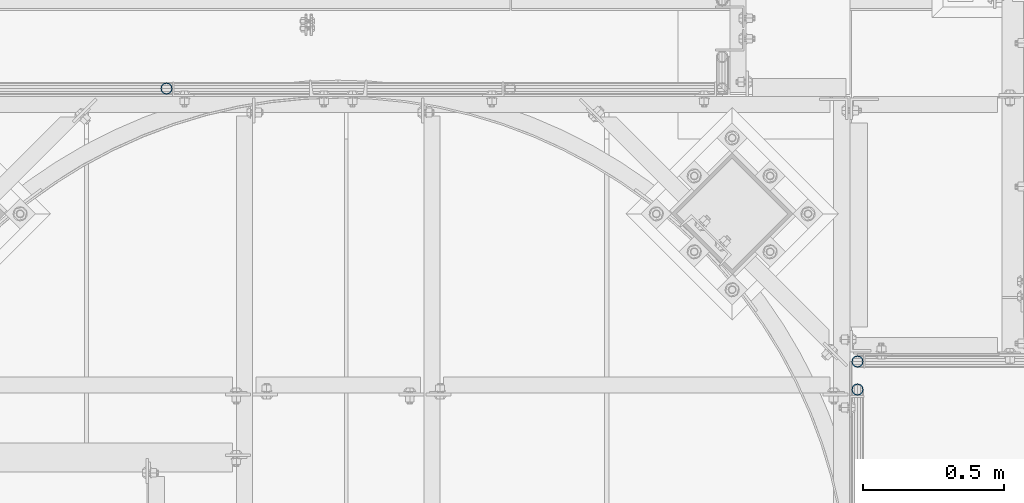
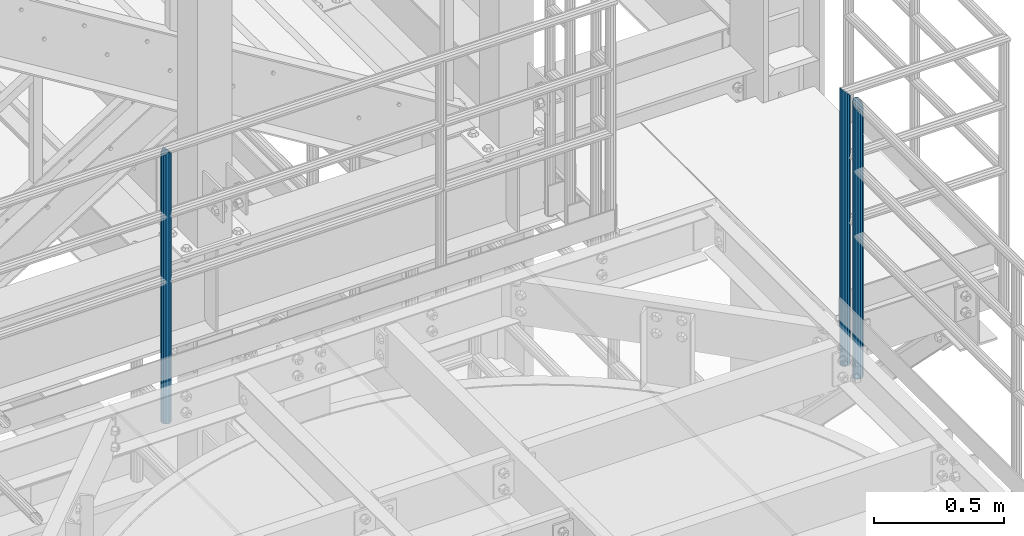
# One storey, part 578 of 1876: 3 columns, 3 elements without a shape of their own.
"""IFC2X3 building model written with IfcOpenShell, lengths in millimetres."""

from ifc_helpers import new_model, si_unit, frame, origin_with_axes, place, context, subcontext, project, spatial, faceted_brep, material, type_object, element, aggregate, save


model = new_model("IFC2X3")

# Units and contexts
model_context = context("Model", 3, precision=1e-05, world=origin_with_axes())
body_context = subcontext(model_context, "Body", "Model", "MODEL_VIEW")
ifc_project = project(units=[si_unit("LENGTHUNIT", "METRE", prefix="MILLI"), si_unit("AREAUNIT", "SQUARE_METRE"), si_unit("VOLUMEUNIT", "CUBIC_METRE"), si_unit("MASSUNIT", "GRAM", prefix="KILO"), si_unit("TIMEUNIT", "SECOND"), si_unit("PLANEANGLEUNIT", "RADIAN"), si_unit("SOLIDANGLEUNIT", "STERADIAN"), si_unit("THERMODYNAMICTEMPERATUREUNIT", "DEGREE_CELSIUS"), si_unit("LUMINOUSINTENSITYUNIT", "LUMEN")], contexts=[model_context])

# Site, building, storey
site_placement = place(None, origin_with_axes())
site = spatial("IfcSite", under=ifc_project, at=site_placement, CompositionType="ELEMENT")
building_placement = place(site_placement, origin_with_axes())
building = spatial("IfcBuilding", under=site, at=building_placement, Name="Undefined", CompositionType="ELEMENT")
storey_placement = place(building_placement, origin_with_axes())
storey = spatial("IfcBuildingStorey", under=building, at=storey_placement, Name="Undefined", CompositionType="ELEMENT", Elevation=0.0)

# Assembly, column
assembly_1_placement = place(storey_placement, origin_with_axes())
assembly_1 = element("IfcElementAssembly", 1, at=assembly_1_placement, inside=storey, Name="HANDRAIL", AssemblyPlace="NOTDEFINED", PredefinedType="RIGID_FRAME")
ifc_material = material()
column_type = type_object("IfcColumnType", Name="PIPE1-1/4STD", PredefinedType="NOTDEFINED")
column_1_placement = place(assembly_1_placement, frame((4572.00474593762, -7694.13240429563, 7813.675), z_axis=(0.0, 1.0, 0.0), x_axis=(0.0, 0.0, 1.0)))
column_1 = element("IfcColumn", 2, at=column_1_placement, type_object=column_type, material=ifc_material, Name="POST", ObjectType="PIPE1-1/4STD", context=body_context, shape_type="Brep", body=[
    faceted_brep([(1276.35, 0.0, -21.0820000000003), (1265.809, 10.5410000000002, -18.2575475625836), (1265.809, -10.5410000000002, -18.2575475625836), (1257.61603877328, 15.1779612267264, 8.76299999999992), (1255.268, 17.5259999999998, 0.0), (1255.268, 21.0820000000003, 0.0), (1258.09245243742, 18.2575475625836, 10.5410000000002), (1258.09245243742, 13.3999612267262, 10.5410000000002), (1258.09245243742, 13.3999612267262, -10.5410000000002), (1258.09245243742, 18.2575475625836, -10.5410000000002), (1257.61603877328, 15.1779612267264, -8.76299999999992), (1262.72937633681, 8.76299999999992, -15.1779612267255), (1265.07741511008, 0.0, -17.5259999999998), (1262.72937633681, -8.76299999999992, -15.1779612267255), (1258.09245243741, -13.3999612267244, -10.541000000002), (1258.09245243742, -18.2575475625836, -10.5409999999993), (1257.61602877145, -15.1779612267264, -8.76300000000083), (1255.268, -17.5259999999998, 0.0), (1255.268, -21.0820000000003, 0.0), (1257.61604877511, -15.1779612267264, 8.76300000000083), (1258.09245243741, -13.399961226728, 10.5409999999983), (1258.09245243742, -18.2575475625836, 10.5409999999993), (1276.35, 0.0, 21.0820000000003), (1265.809, -10.5410000000002, 18.2575475625836), (1265.809, 10.5410000000002, 18.2575475625836), (1262.72941366414, -8.76299999999992, 15.1779612267264), (1265.07745243742, 0.0, 17.5259999999998), (1262.72941366414, 8.76299999999992, 15.1779612267264), (0.0, -18.2575475625836, -10.5409999999993), (0.0, -10.5410000000002, -18.2575475625836), (-4.28826751885936e-09, 0.0, -21.0820000000003), (0.0, 10.5410000000002, -18.2575475625836), (0.0, 18.2575475625836, -10.5409999999993), (9.09494701772928e-13, 21.0820000000003, 0.0), (0.0, 18.2575475625836, 10.5409999999993), (0.0, 10.5410000000002, 18.2575475625836), (0.0, 0.0, 21.0820000000003), (0.0, -18.2575475625836, 10.5409999999993), (9.09494701772928e-13, -21.0820000000003, 0.0), (0.0, -10.5410000000002, 18.2575475625836), (0.0, -15.1779612267264, -8.76300000000083), (0.0, -8.76299999999992, -15.1779612267255), (0.0, 0.0, -17.5259999999998), (0.0, 8.76299999999992, -15.1779612267255), (0.0, 15.1779612267264, -8.76300000000083), (0.0, 17.5259999999998, 0.0), (0.0, 15.1779612267264, 8.76300000000083), (0.0, 8.76299999999992, 15.1779612267255), (0.0, 0.0, 17.5259999999998), (0.0, -8.76299999999992, 15.1779612267255), (0.0, -15.1779612267264, 8.76300000000083), (0.0, -17.5259999999998, 0.0)], [[[0, 1, 2]], [[3, 4, 5, 6, 7]], [[8, 9, 5, 4, 10]], [[2, 1, 9, 8, 11, 12, 13, 14, 15]], [[15, 14, 16, 17, 18]], [[18, 17, 19, 20, 21]], [[22, 23, 24]], [[21, 20, 25, 26, 27, 7, 6, 24, 23]], [[28, 29, 2, 15]], [[29, 30, 0, 2]], [[30, 31, 1, 0]], [[31, 32, 9, 1]], [[32, 33, 5, 9]], [[33, 34, 6, 5]], [[34, 35, 24, 6]], [[35, 36, 22, 24]], [[37, 38, 18, 21]], [[39, 37, 21, 23]], [[36, 39, 23, 22]], [[38, 28, 15, 18]], [[37, 39, 36, 35, 34, 33, 32, 31, 30, 29, 28, 38], [40, 41, 42, 43, 44, 45, 46, 47, 48, 49, 50, 51]], [[49, 48, 26, 25]], [[19, 50, 49, 25, 20]], [[51, 50, 19, 17]], [[40, 51, 17, 16]], [[41, 40, 16, 14, 13]], [[42, 41, 13, 12]], [[43, 42, 12, 11]], [[10, 44, 43, 11, 8]], [[45, 44, 10, 4]], [[46, 45, 4, 3]], [[47, 46, 3, 7, 27]], [[48, 47, 27, 26]]]),
])
aggregate(assembly_1, [column_1])

assembly_2_placement = place(storey_placement, origin_with_axes())
assembly_2 = element("IfcElementAssembly", 3, at=assembly_2_placement, inside=storey, Name="HANDRAIL", AssemblyPlace="NOTDEFINED", PredefinedType="RIGID_FRAME")
column_2_placement = place(assembly_2_placement, frame((7025.13388293519, -8663.432, 7813.675), z_axis=(0.0, 1.0, 0.0), x_axis=(0.0, 0.0, 1.0)))
column_2 = element("IfcColumn", 4, at=column_2_placement, type_object=column_type, material=ifc_material, Name="POST", ObjectType="PIPE1-1/4STD", context=body_context, shape_type="Brep", body=[
    faceted_brep([(0.0, -17.5259999999998, 0.0), (0.0, -15.1779612267264, 8.76300000000083), (1291.52796122673, -15.1779612267264, 8.76300000000083), (1293.876, -17.5259999999998, 0.0), (0.0, -8.76299999999992, 15.1779612267255), (1285.113, -8.76299999999992, 15.1779612267255), (0.0, 0.0, 17.5259999999998), (1276.35, 0.0, 17.5259999999998), (0.0, 8.76299999999992, 15.1779612267255), (1267.587, 8.76299999999992, 15.1779612267255), (0.0, 15.1779612267264, 8.76300000000083), (1261.17203877328, 15.1779612267264, 8.76300000000083), (0.0, 17.5259999999998, 0.0), (1258.824, 17.5259999999998, 0.0), (0.0, 15.1779612267264, -8.76300000000083), (1261.17203877328, 15.1779612267264, -8.76300000000083), (0.0, 8.76299999999992, -15.1779612267255), (1267.587, 8.76299999999992, -15.1779612267255), (0.0, 0.0, -17.5259999999998), (1276.35, 0.0, -17.5259999999998), (0.0, -8.76299999999992, -15.1779612267255), (1285.113, -8.76299999999992, -15.1779612267255), (0.0, -15.1779612267264, -8.76300000000083), (1291.52796122673, -15.1779612267264, -8.76300000000083), (9.09494701772928e-13, -21.0820000000003, 0.0), (0.0, -18.2575475625836, -10.5409999999993), (1294.60754756258, -18.2575475625836, -10.5409999999993), (1297.432, -21.0820000000003, 0.0), (0.0, -10.5410000000002, -18.2575475625836), (1286.891, -10.5410000000002, -18.2575475625836), (-4.28826751885936e-09, 0.0, -21.0820000000003), (1276.35, 0.0, -21.0820000000003), (0.0, 10.5410000000002, -18.2575475625836), (1265.809, 10.5410000000002, -18.2575475625836), (0.0, 18.2575475625836, -10.5409999999993), (1258.09245243742, 18.2575475625836, -10.5410000000002), (9.09494701772928e-13, 21.0820000000003, 0.0), (1255.268, 21.0820000000003, 0.0), (0.0, 18.2575475625836, 10.5409999999993), (1258.09245243742, 18.2575475625836, 10.5410000000002), (0.0, 10.5410000000002, 18.2575475625836), (1265.809, 10.5410000000002, 18.2575475625836), (0.0, 0.0, 21.0820000000003), (1276.35, 0.0, 21.0820000000003), (0.0, -10.5410000000002, 18.2575475625836), (1286.891, -10.5410000000002, 18.2575475625836), (0.0, -18.2575475625836, 10.5409999999993), (1294.60754756258, -18.2575475625836, 10.5409999999993)], [[[0, 1, 2, 3]], [[1, 4, 5, 2]], [[4, 6, 7, 5]], [[6, 8, 9, 7]], [[8, 10, 11, 9]], [[10, 12, 13, 11]], [[12, 14, 15, 13]], [[14, 16, 17, 15]], [[16, 18, 19, 17]], [[18, 20, 21, 19]], [[20, 22, 23, 21]], [[22, 0, 3, 23]], [[24, 25, 26, 27]], [[25, 28, 29, 26]], [[28, 30, 31, 29]], [[30, 32, 33, 31]], [[32, 34, 35, 33]], [[34, 36, 37, 35]], [[36, 38, 39, 37]], [[38, 40, 41, 39]], [[40, 42, 43, 41]], [[42, 44, 45, 43]], [[44, 46, 47, 45]], [[46, 24, 27, 47]], [[29, 31, 33, 35, 37, 39, 41, 43, 45, 47, 27, 26], [5, 7, 9, 11, 13, 15, 17, 19, 21, 23, 3, 2]], [[46, 44, 42, 40, 38, 36, 34, 32, 30, 28, 25, 24], [22, 20, 18, 16, 14, 12, 10, 8, 6, 4, 1, 0]]]),
])
aggregate(assembly_2, [column_2])

assembly_3_placement = place(storey_placement, origin_with_axes())
assembly_3 = element("IfcElementAssembly", 5, at=assembly_3_placement, inside=storey, Name="HANDRAIL", AssemblyPlace="NOTDEFINED", PredefinedType="RIGID_FRAME")
column_3_placement = place(assembly_3_placement, frame((7025.13388293519, -8762.96435546873, 7813.675), z_axis=(0.0, 1.0, 0.0), x_axis=(0.0, 0.0, 1.0)))
column_3 = element("IfcColumn", 6, at=column_3_placement, type_object=column_type, material=ifc_material, Name="POST", ObjectType="PIPE1-1/4STD", context=body_context, shape_type="Brep", body=[
    faceted_brep([(0.0, -17.5259999999998, 0.0), (0.0, -15.1779612267264, 8.76300000000083), (1285.11300200349, -15.1779612267264, 8.76299999999992), (1276.35000231344, -17.5259999999998, 0.0), (0.0, -8.76299999999992, 15.1779612267255), (1291.52796238344, -8.76299999999992, 15.1779612267264), (0.0, 0.0, 17.5259999999998), (1293.876, 0.0, 17.5259999999998), (0.0, 8.76299999999992, 15.1779612267255), (1291.52796007001, 8.76299999999992, 15.1779612267264), (0.0, 15.1779612267264, 8.76300000000083), (1285.11299799651, 15.1779612267264, 8.76299999999992), (0.0, 17.5259999999998, 0.0), (1276.34999768657, 17.5259999999998, 0.0), (0.0, 15.1779612267264, -8.76300000000083), (1267.58699799651, 15.1779612267264, -8.76299999999992), (0.0, 8.76299999999992, -15.1779612267255), (1261.17203761656, 8.76299999999992, -15.1779612267264), (0.0, 0.0, -17.5259999999998), (1258.824, 0.0, -17.5259999999998), (0.0, -8.76299999999992, -15.1779612267255), (1261.17203992999, -8.76299999999992, -15.1779612267264), (0.0, -15.1779612267264, -8.76300000000083), (1267.58700200349, -15.1779612267264, -8.76299999999992), (9.09494701772928e-13, -21.0820000000003, 0.0), (0.0, -18.2575475625836, -10.5409999999993), (1265.809, -18.2575475625836, -10.5410000000002), (1276.35000278283, -21.0820000000003, 0.0), (0.0, -10.5410000000002, -18.2575475625836), (1258.09245243742, -10.5410000000002, -18.2575475625836), (-4.28826751885936e-09, 0.0, -21.0820000000003), (1255.268, 0.0, -21.0820000000003), (0.0, 10.5410000000002, -18.2575475625836), (1258.09245243742, 10.5410000000002, -18.2575475625836), (0.0, 18.2575475625836, -10.5409999999993), (1265.809, 18.2575475625836, -10.5410000000002), (9.09494701772928e-13, 21.0820000000003, 0.0), (1276.35, 21.0820000000003, 0.0), (0.0, 18.2575475625836, 10.5409999999993), (1286.89099759001, 18.2575475625836, 10.5410000000002), (0.0, 10.5410000000002, 18.2575475625836), (1294.60754617117, 10.5410000000002, 18.2575475625836), (0.0, 0.0, 21.0820000000003), (1297.432, 0.0, 21.0820000000003), (0.0, -10.5410000000002, 18.2575475625836), (1294.607548954, -10.5410000000002, 18.2575475625836), (0.0, -18.2575475625836, 10.5409999999993), (1286.89100241, -18.2575475625836, 10.5410000000002)], [[[0, 1, 2, 3]], [[1, 4, 5, 2]], [[4, 6, 7, 5]], [[6, 8, 9, 7]], [[8, 10, 11, 9]], [[10, 12, 13, 11]], [[12, 14, 15, 13]], [[14, 16, 17, 15]], [[16, 18, 19, 17]], [[18, 20, 21, 19]], [[20, 22, 23, 21]], [[22, 0, 3, 23]], [[24, 25, 26, 27]], [[25, 28, 29, 26]], [[28, 30, 31, 29]], [[30, 32, 33, 31]], [[32, 34, 35, 33]], [[34, 36, 37, 35]], [[36, 38, 39, 37]], [[38, 40, 41, 39]], [[40, 42, 43, 41]], [[42, 44, 45, 43]], [[44, 46, 47, 45]], [[46, 24, 27, 47]], [[29, 31, 33, 35, 37, 39, 41, 43, 45, 47, 27, 26], [5, 7, 9, 11, 13, 15, 17, 19, 21, 23, 3, 2]], [[46, 44, 42, 40, 38, 36, 34, 32, 30, 28, 25, 24], [22, 20, 18, 16, 14, 12, 10, 8, 6, 4, 1, 0]]]),
])
aggregate(assembly_3, [column_3])

save(model, "model.ifc")
